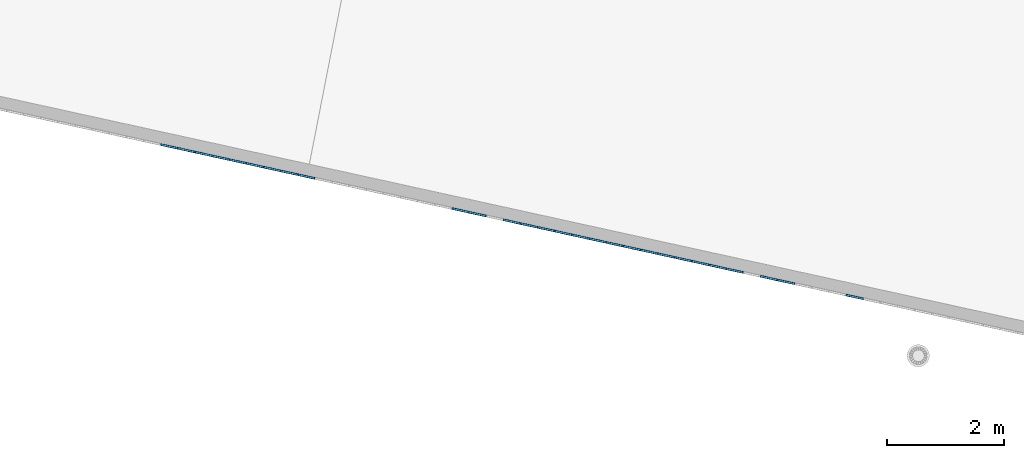
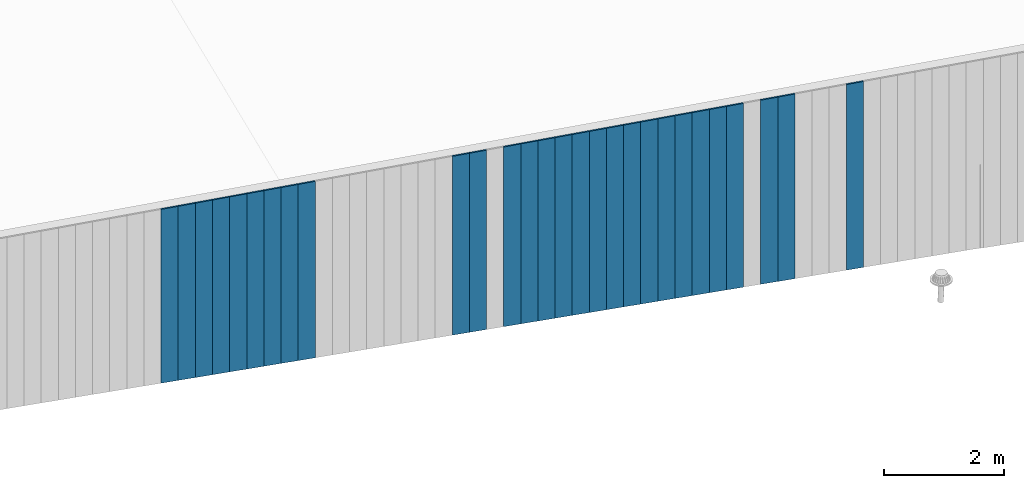
# One storey, part 4 of 18: 28 plates, 1 element without a shape of its own.
"""IFC2X3 building model written with IfcOpenShell, lengths in centimetres."""

from ifc_helpers import new_model, entity, si_unit, converted_unit, derived_unit, direction, frame, origin, place, context, subcontext, project, spatial, polyline, outline, extrude, source, transform, mapped, material, layer, layer_set, layer_usage, type_object, type_shapes, element, aggregate, save


model = new_model("IFC2X3")

# Units and contexts
model_context = context("Model", 3, precision=0.001, world=origin(), true_north=direction((6.12303176911189e-17, 1.0)))
body_context = subcontext(model_context, "Body", "Model", "MODEL_VIEW")
ifc_project = project(units=[si_unit("LENGTHUNIT", "METRE", prefix="CENTI"), si_unit("AREAUNIT", "SQUARE_METRE"), si_unit("VOLUMEUNIT", "CUBIC_METRE"), converted_unit("PLANEANGLEUNIT", "DEGREE", entity("IfcRatioMeasure", 0.0174532925199433), si_unit("PLANEANGLEUNIT", "RADIAN"), dimensions=[0, 0, 0, 0, 0, 0, 0]), si_unit("MASSUNIT", "GRAM", prefix="KILO"), derived_unit("MASSDENSITYUNIT", [(si_unit("MASSUNIT", "GRAM", prefix="KILO"), 1), (si_unit("LENGTHUNIT", "METRE"), -3)]), si_unit("TIMEUNIT", "SECOND"), si_unit("FREQUENCYUNIT", "HERTZ"), si_unit("THERMODYNAMICTEMPERATUREUNIT", "DEGREE_CELSIUS"), derived_unit("THERMALTRANSMITTANCEUNIT", [(si_unit("MASSUNIT", "GRAM", prefix="KILO"), 1), (si_unit("THERMODYNAMICTEMPERATUREUNIT", "KELVIN"), -1), (si_unit("TIMEUNIT", "SECOND"), -3)]), derived_unit("VOLUMETRICFLOWRATEUNIT", [(si_unit("LENGTHUNIT", "METRE"), 3), (si_unit("TIMEUNIT", "SECOND"), -1)]), si_unit("ELECTRICCURRENTUNIT", "AMPERE"), si_unit("ELECTRICVOLTAGEUNIT", "VOLT"), si_unit("POWERUNIT", "WATT"), si_unit("FORCEUNIT", "NEWTON", prefix="KILO"), si_unit("ILLUMINANCEUNIT", "LUX"), si_unit("LUMINOUSFLUXUNIT", "LUMEN"), si_unit("LUMINOUSINTENSITYUNIT", "CANDELA"), derived_unit("USERDEFINED", [(si_unit("MASSUNIT", "GRAM", prefix="KILO"), -1), (si_unit("LENGTHUNIT", "METRE"), -2), (si_unit("TIMEUNIT", "SECOND"), 3), (si_unit("LUMINOUSFLUXUNIT", "LUMEN"), 1)]), derived_unit("LINEARVELOCITYUNIT", [(si_unit("LENGTHUNIT", "METRE"), 1), (si_unit("TIMEUNIT", "SECOND"), -1)]), si_unit("PRESSUREUNIT", "PASCAL"), derived_unit("USERDEFINED", [(si_unit("LENGTHUNIT", "METRE"), -2), (si_unit("MASSUNIT", "GRAM", prefix="KILO"), 1), (si_unit("TIMEUNIT", "SECOND"), -2)])], contexts=[model_context])

# Site, building, storey
site_placement = place(None, origin())
site = spatial("IfcSite", under=ifc_project, at=site_placement, CompositionType="ELEMENT")
building_placement = place(site_placement, origin())
building = spatial("IfcBuilding", under=site, at=building_placement, CompositionType="ELEMENT")
storey_placement = place(building_placement, frame((0.0, 0.0, 1422.0)))
storey = spatial("IfcBuildingStorey", under=building, at=storey_placement, CompositionType="ELEMENT", Elevation=1422.0)

# Curtain wall, plates
curtain_wall_type = type_object("IfcCurtainWallType", PredefinedType="NOTDEFINED")
curtain_wall_placement = place(storey_placement, frame((0.0, 0.0, -1422.0)))
curtain_wall = element("IfcCurtainWall", 1, at=curtain_wall_placement, inside=storey, type_object=curtain_wall_type)
ifc_material = material()
ifc_layer = layer(ifc_material, 3.0)
ifc_layer_set = layer_set([ifc_layer])
ifc_layer_usage_1 = layer_usage(ifc_layer_set, "AXIS3", "POSITIVE", 0.0492125984251968)
plate_type_1 = type_object("IfcPlateType", Name="Panneau plein ST", PredefinedType="CURTAIN_PANEL", material=ifc_layer_set)
shared_shape_1 = source(origin(), body_context, "Body", "SweptSolid", [
    extrude(outline(polyline([(-189.503283067157, -15.0), (189.203717939239, -15.0), (189.203717939239, 15.0), (-188.904152811321, 15.0), (-189.503283067157, -15.0)])), frame((0.0, 0.0, 189.503283067157), z_axis=(0.0, 1.0, 0.0), x_axis=(0.0, 0.0, 1.0)), (0.0, 0.0, 1.0), 3.0),
])
type_shapes(plate_type_1, [shared_shape_1])
plate_1_placement = place(curtain_wall_placement, frame((7422.72421840051, 342.71127905933, 1043.2929989936), z_axis=(0.0, 0.0, 1.0), x_axis=(-0.976731958442773, 0.214463706385357, 0.0)))
plate_1 = element("IfcPlate", 2, at=plate_1_placement, type_object=plate_type_1, material=ifc_layer_usage_1, ObjectType="Panneau plein ST", context=body_context, shape_type="MappedRepresentation", body=[
    mapped(shared_shape_1, transform((0.0, 0.0, 0.0), scale=1.0)),
])
ifc_layer_usage_2 = layer_usage(ifc_layer_set, "AXIS3", "POSITIVE", 0.0492125984251968)
plate_type_2 = type_object("IfcPlateType", Name="Panneau plein ST", PredefinedType="CURTAIN_PANEL", material=ifc_layer_set)
shared_shape_2 = source(origin(), body_context, "Body", "SweptSolid", [
    extrude(outline(polyline([(-188.305022555485, -15.0), (188.005457427567, -15.0), (188.005457427567, 15.0), (-187.705892299649, 15.0), (-188.305022555485, -15.0)])), frame((0.0, 0.0, 188.305022555485), z_axis=(0.0, 1.0, 0.0), x_axis=(0.0, 0.0, 1.0)), (0.0, 0.0, 1.0), 3.0),
])
type_shapes(plate_type_2, [shared_shape_2])
plate_2_placement = place(curtain_wall_placement, frame((7305.51638338737, 368.446923825572, 1045.68952001695), z_axis=(0.0, 0.0, 1.0), x_axis=(-0.976731958442773, 0.214463706385357, 0.0)))
plate_2 = element("IfcPlate", 3, at=plate_2_placement, type_object=plate_type_2, material=ifc_layer_usage_2, ObjectType="Panneau plein ST", context=body_context, shape_type="MappedRepresentation", body=[
    mapped(shared_shape_2, transform((0.0, 0.0, 0.0), scale=1.0)),
])
ifc_layer_usage_3 = layer_usage(ifc_layer_set, "AXIS3", "POSITIVE", 0.0492125984251968)
plate_type_3 = type_object("IfcPlateType", Name="Panneau plein ST", PredefinedType="CURTAIN_PANEL", material=ifc_layer_set)
shared_shape_3 = source(origin(), body_context, "Body", "SweptSolid", [
    extrude(outline(polyline([(-188.005457427567, -15.0), (187.705892299649, -15.0), (187.705892299649, 15.0), (-187.406327171731, 15.0), (-188.005457427567, -15.0)])), frame((0.0, 0.0, 188.005457427567), z_axis=(0.0, 1.0, 0.0), x_axis=(0.0, 0.0, 1.0)), (0.0, 0.0, 1.0), 3.0),
])
type_shapes(plate_type_3, [shared_shape_3])
plate_3_placement = place(curtain_wall_placement, frame((7276.21442463409, 374.880835017134, 1046.28865027278), z_axis=(0.0, 0.0, 1.0), x_axis=(-0.976731958442773, 0.214463706385357, 0.0)))
plate_3 = element("IfcPlate", 4, at=plate_3_placement, type_object=plate_type_3, material=ifc_layer_usage_3, ObjectType="Panneau plein ST", context=body_context, shape_type="MappedRepresentation", body=[
    mapped(shared_shape_3, transform((0.0, 0.0, 0.0), scale=1.0)),
])
ifc_layer_usage_4 = layer_usage(ifc_layer_set, "AXIS3", "POSITIVE", 0.0492125984251968)
plate_type_4 = type_object("IfcPlateType", Name="Panneau plein ST", PredefinedType="CURTAIN_PANEL", material=ifc_layer_set)
shared_shape_4 = source(origin(), body_context, "Body", "SweptSolid", [
    extrude(outline(polyline([(-187.406327171731, -15.0), (187.106762043813, -15.0), (187.106762043813, 15.0), (-186.807196915895, 15.0), (-187.406327171731, -15.0)])), frame((0.0, 0.0, 187.406327171731), z_axis=(0.0, 1.0, 0.0), x_axis=(0.0, 0.0, 1.0)), (0.0, 0.0, 1.0), 3.0),
])
type_shapes(plate_type_4, [shared_shape_4])
plate_4_placement = place(curtain_wall_placement, frame((7217.61050712753, 387.748657400255, 1047.48691078446), z_axis=(0.0, 0.0, 1.0), x_axis=(-0.976731958442773, 0.214463706385357, 0.0)))
plate_4 = element("IfcPlate", 5, at=plate_4_placement, type_object=plate_type_4, material=ifc_layer_usage_4, ObjectType="Panneau plein ST", context=body_context, shape_type="MappedRepresentation", body=[
    mapped(shared_shape_4, transform((0.0, 0.0, 0.0), scale=1.0)),
])
ifc_layer_usage_5 = layer_usage(ifc_layer_set, "AXIS3", "POSITIVE", 0.0492125984251968)
plate_type_5 = type_object("IfcPlateType", Name="Panneau plein ST", PredefinedType="CURTAIN_PANEL", material=ifc_layer_set)
shared_shape_5 = source(origin(), body_context, "Body", "SweptSolid", [
    extrude(outline(polyline([(-187.106762043813, -15.0), (186.807196915895, -15.0), (186.807196915895, 15.0), (-186.507631787977, 15.0), (-187.106762043813, -15.0)])), frame((0.0, 0.0, 187.106762043813), z_axis=(0.0, 1.0, 0.0), x_axis=(0.0, 0.0, 1.0)), (0.0, 0.0, 1.0), 3.0),
])
type_shapes(plate_type_5, [shared_shape_5])
plate_5_placement = place(curtain_wall_placement, frame((7188.30854837424, 394.182568591816, 1048.08604104029), z_axis=(0.0, 0.0, 1.0), x_axis=(-0.976731958442773, 0.214463706385357, 0.0)))
plate_5 = element("IfcPlate", 6, at=plate_5_placement, type_object=plate_type_5, material=ifc_layer_usage_5, ObjectType="Panneau plein ST", context=body_context, shape_type="MappedRepresentation", body=[
    mapped(shared_shape_5, transform((0.0, 0.0, 0.0), scale=1.0)),
])
ifc_layer_usage_6 = layer_usage(ifc_layer_set, "AXIS3", "POSITIVE", 0.0492125984251968)
plate_type_6 = type_object("IfcPlateType", Name="Panneau plein ST", PredefinedType="CURTAIN_PANEL", material=ifc_layer_set)
shared_shape_6 = source(origin(), body_context, "Body", "SweptSolid", [
    extrude(outline(polyline([(-186.807196915895, -15.0), (186.507631787977, -15.0), (186.507631787977, 15.0), (-186.208066660059, 15.0), (-186.807196915895, -15.0)])), frame((0.0, 0.0, 186.807196915895), z_axis=(0.0, 1.0, 0.0), x_axis=(0.0, 0.0, 1.0)), (0.0, 0.0, 1.0), 3.0),
])
type_shapes(plate_type_6, [shared_shape_6])
plate_6_placement = place(curtain_wall_placement, frame((7159.00658962096, 400.616479783376, 1048.68517129613), z_axis=(0.0, 0.0, 1.0), x_axis=(-0.976731958442773, 0.214463706385357, 0.0)))
plate_6 = element("IfcPlate", 7, at=plate_6_placement, type_object=plate_type_6, material=ifc_layer_usage_6, ObjectType="Panneau plein ST", context=body_context, shape_type="MappedRepresentation", body=[
    mapped(shared_shape_6, transform((0.0, 0.0, 0.0), scale=1.0)),
])
ifc_layer_usage_7 = layer_usage(ifc_layer_set, "AXIS3", "POSITIVE", 0.0492125984251968)
plate_type_7 = type_object("IfcPlateType", Name="Panneau plein ST", PredefinedType="CURTAIN_PANEL", material=ifc_layer_set)
shared_shape_7 = source(origin(), body_context, "Body", "SweptSolid", [
    extrude(outline(polyline([(-186.507631787977, -15.0), (186.208066660059, -15.0), (186.208066660059, 15.0), (-185.908501532141, 15.0), (-186.507631787977, -15.0)])), frame((0.0, 0.0, 186.507631787977), z_axis=(0.0, 1.0, 0.0), x_axis=(0.0, 0.0, 1.0)), (0.0, 0.0, 1.0), 3.0),
])
type_shapes(plate_type_7, [shared_shape_7])
plate_7_placement = place(curtain_wall_placement, frame((7129.70463086767, 407.050390974937, 1049.28430155196), z_axis=(0.0, 0.0, 1.0), x_axis=(-0.976731958442773, 0.214463706385357, 0.0)))
plate_7 = element("IfcPlate", 8, at=plate_7_placement, type_object=plate_type_7, material=ifc_layer_usage_7, ObjectType="Panneau plein ST", context=body_context, shape_type="MappedRepresentation", body=[
    mapped(shared_shape_7, transform((0.0, 0.0, 0.0), scale=1.0)),
])
ifc_layer_usage_8 = layer_usage(ifc_layer_set, "AXIS3", "POSITIVE", 0.0492125984251968)
plate_type_8 = type_object("IfcPlateType", Name="Panneau plein ST", PredefinedType="CURTAIN_PANEL", material=ifc_layer_set)
shared_shape_8 = source(origin(), body_context, "Body", "SweptSolid", [
    extrude(outline(polyline([(-186.208066660059, -15.0), (185.908501532141, -15.0), (185.908501532141, 15.0), (-185.608936404223, 15.0), (-186.208066660059, -15.0)])), frame((0.0, 0.0, 186.208066660059), z_axis=(0.0, 1.0, 0.0), x_axis=(0.0, 0.0, 1.0)), (0.0, 0.0, 1.0), 3.0),
])
type_shapes(plate_type_8, [shared_shape_8])
plate_8_placement = place(curtain_wall_placement, frame((7100.40267211439, 413.484302166498, 1049.8834318078), z_axis=(0.0, 0.0, 1.0), x_axis=(-0.976731958442773, 0.214463706385357, 0.0)))
plate_8 = element("IfcPlate", 9, at=plate_8_placement, type_object=plate_type_8, material=ifc_layer_usage_8, ObjectType="Panneau plein ST", context=body_context, shape_type="MappedRepresentation", body=[
    mapped(shared_shape_8, transform((0.0, 0.0, 0.0), scale=1.0)),
])
ifc_layer_usage_9 = layer_usage(ifc_layer_set, "AXIS3", "POSITIVE", 0.0492125984251968)
plate_type_9 = type_object("IfcPlateType", Name="Panneau plein ST", PredefinedType="CURTAIN_PANEL", material=ifc_layer_set)
shared_shape_9 = source(origin(), body_context, "Body", "SweptSolid", [
    extrude(outline(polyline([(-185.908501532141, -15.0), (185.608936404223, -15.0), (185.608936404223, 15.0), (-185.309371276305, 15.0), (-185.908501532141, -15.0)])), frame((0.0, 0.0, 185.908501532141), z_axis=(0.0, 1.0, 0.0), x_axis=(0.0, 0.0, 1.0)), (0.0, 0.0, 1.0), 3.0),
])
type_shapes(plate_type_9, [shared_shape_9])
plate_9_placement = place(curtain_wall_placement, frame((7071.10071336111, 419.918213358058, 1050.48256206364), z_axis=(0.0, 0.0, 1.0), x_axis=(-0.976731958442773, 0.214463706385357, 0.0)))
plate_9 = element("IfcPlate", 10, at=plate_9_placement, type_object=plate_type_9, material=ifc_layer_usage_9, ObjectType="Panneau plein ST", context=body_context, shape_type="MappedRepresentation", body=[
    mapped(shared_shape_9, transform((0.0, 0.0, 0.0), scale=1.0)),
])
ifc_layer_usage_10 = layer_usage(ifc_layer_set, "AXIS3", "POSITIVE", 0.0492125984251968)
plate_type_10 = type_object("IfcPlateType", Name="Panneau plein ST", PredefinedType="CURTAIN_PANEL", material=ifc_layer_set)
shared_shape_10 = source(origin(), body_context, "Body", "SweptSolid", [
    extrude(outline(polyline([(-185.608936404223, -15.0), (185.309371276305, -15.0), (185.309371276305, 15.0), (-185.009806148387, 15.0), (-185.608936404223, -15.0)])), frame((0.0, 0.0, 185.608936404223), z_axis=(0.0, 1.0, 0.0), x_axis=(0.0, 0.0, 1.0)), (0.0, 0.0, 1.0), 3.0),
])
type_shapes(plate_type_10, [shared_shape_10])
plate_10_placement = place(curtain_wall_placement, frame((7041.79875460782, 426.352124549619, 1051.08169231947), z_axis=(0.0, 0.0, 1.0), x_axis=(-0.976731958442773, 0.214463706385357, 0.0)))
plate_10 = element("IfcPlate", 11, at=plate_10_placement, type_object=plate_type_10, material=ifc_layer_usage_10, ObjectType="Panneau plein ST", context=body_context, shape_type="MappedRepresentation", body=[
    mapped(shared_shape_10, transform((0.0, 0.0, 0.0), scale=1.0)),
])
ifc_layer_usage_11 = layer_usage(ifc_layer_set, "AXIS3", "POSITIVE", 0.0492125984251968)
plate_type_11 = type_object("IfcPlateType", Name="Panneau plein ST", PredefinedType="CURTAIN_PANEL", material=ifc_layer_set)
shared_shape_11 = source(origin(), body_context, "Body", "SweptSolid", [
    extrude(outline(polyline([(-185.309371276305, -15.0), (185.009806148387, -15.0), (185.009806148387, 15.0), (-184.710241020469, 15.0), (-185.309371276305, -15.0)])), frame((0.0, 0.0, 185.309371276305), z_axis=(0.0, 1.0, 0.0), x_axis=(0.0, 0.0, 1.0)), (0.0, 0.0, 1.0), 3.0),
])
type_shapes(plate_type_11, [shared_shape_11])
plate_11_placement = place(curtain_wall_placement, frame((7012.49679585454, 432.78603574118, 1051.68082257531), z_axis=(0.0, 0.0, 1.0), x_axis=(-0.976731958442773, 0.214463706385357, 0.0)))
plate_11 = element("IfcPlate", 12, at=plate_11_placement, type_object=plate_type_11, material=ifc_layer_usage_11, ObjectType="Panneau plein ST", context=body_context, shape_type="MappedRepresentation", body=[
    mapped(shared_shape_11, transform((0.0, 0.0, 0.0), scale=1.0)),
])
ifc_layer_usage_12 = layer_usage(ifc_layer_set, "AXIS3", "POSITIVE", 0.0492125984251968)
plate_type_12 = type_object("IfcPlateType", Name="Panneau plein ST", PredefinedType="CURTAIN_PANEL", material=ifc_layer_set)
shared_shape_12 = source(origin(), body_context, "Body", "SweptSolid", [
    extrude(outline(polyline([(-185.009806148387, -15.0), (184.710241020469, -15.0), (184.710241020469, 15.0), (-184.410675892551, 15.0), (-185.009806148387, -15.0)])), frame((0.0, 0.0, 185.009806148387), z_axis=(0.0, 1.0, 0.0), x_axis=(0.0, 0.0, 1.0)), (0.0, 0.0, 1.0), 3.0),
])
type_shapes(plate_type_12, [shared_shape_12])
plate_12_placement = place(curtain_wall_placement, frame((6983.19483710126, 439.219946932741, 1052.27995283114), z_axis=(0.0, 0.0, 1.0), x_axis=(-0.976731958442773, 0.214463706385357, 0.0)))
plate_12 = element("IfcPlate", 13, at=plate_12_placement, type_object=plate_type_12, material=ifc_layer_usage_12, ObjectType="Panneau plein ST", context=body_context, shape_type="MappedRepresentation", body=[
    mapped(shared_shape_12, transform((0.0, 0.0, 0.0), scale=1.0)),
])
ifc_layer_usage_13 = layer_usage(ifc_layer_set, "AXIS3", "POSITIVE", 0.0492125984251968)
plate_type_13 = type_object("IfcPlateType", Name="Panneau plein ST", PredefinedType="CURTAIN_PANEL", material=ifc_layer_set)
shared_shape_13 = source(origin(), body_context, "Body", "SweptSolid", [
    extrude(outline(polyline([(-184.710241020469, -15.0), (184.410675892551, -15.0), (184.410675892551, 15.0), (-184.111110764633, 15.0), (-184.710241020469, -15.0)])), frame((0.0, 0.0, 184.710241020469), z_axis=(0.0, 1.0, 0.0), x_axis=(0.0, 0.0, 1.0)), (0.0, 0.0, 1.0), 3.0),
])
type_shapes(plate_type_13, [shared_shape_13])
plate_13_placement = place(curtain_wall_placement, frame((6953.89287834797, 445.653858124301, 1052.87908308698), z_axis=(0.0, 0.0, 1.0), x_axis=(-0.976731958442773, 0.214463706385357, 0.0)))
plate_13 = element("IfcPlate", 14, at=plate_13_placement, type_object=plate_type_13, material=ifc_layer_usage_13, ObjectType="Panneau plein ST", context=body_context, shape_type="MappedRepresentation", body=[
    mapped(shared_shape_13, transform((0.0, 0.0, 0.0), scale=1.0)),
])
ifc_layer_usage_14 = layer_usage(ifc_layer_set, "AXIS3", "POSITIVE", 0.0492125984251968)
plate_type_14 = type_object("IfcPlateType", Name="Panneau plein ST", PredefinedType="CURTAIN_PANEL", material=ifc_layer_set)
shared_shape_14 = source(origin(), body_context, "Body", "SweptSolid", [
    extrude(outline(polyline([(-184.410675892551, -15.0), (184.111110764633, -15.0), (184.111110764633, 15.0), (-183.811545636715, 15.0), (-184.410675892551, -15.0)])), frame((0.0, 0.0, 184.410675892551), z_axis=(0.0, 1.0, 0.0), x_axis=(0.0, 0.0, 1.0)), (0.0, 0.0, 1.0), 3.0),
])
type_shapes(plate_type_14, [shared_shape_14])
plate_14_placement = place(curtain_wall_placement, frame((6924.59091959469, 452.087769315862, 1053.47821334282), z_axis=(0.0, 0.0, 1.0), x_axis=(-0.976731958442773, 0.214463706385357, 0.0)))
plate_14 = element("IfcPlate", 15, at=plate_14_placement, type_object=plate_type_14, material=ifc_layer_usage_14, ObjectType="Panneau plein ST", context=body_context, shape_type="MappedRepresentation", body=[
    mapped(shared_shape_14, transform((0.0, 0.0, 0.0), scale=1.0)),
])
ifc_layer_usage_15 = layer_usage(ifc_layer_set, "AXIS3", "POSITIVE", 0.0492125984251968)
plate_type_15 = type_object("IfcPlateType", Name="Panneau plein ST", PredefinedType="CURTAIN_PANEL", material=ifc_layer_set)
shared_shape_15 = source(origin(), body_context, "Body", "SweptSolid", [
    extrude(outline(polyline([(-184.111110764633, -15.0), (183.811545636715, -15.0), (183.811545636715, 15.0), (-183.511980508797, 15.0), (-184.111110764633, -15.0)])), frame((0.0, 0.0, 184.111110764633), z_axis=(0.0, 1.0, 0.0), x_axis=(0.0, 0.0, 1.0)), (0.0, 0.0, 1.0), 3.0),
])
type_shapes(plate_type_15, [shared_shape_15])
plate_15_placement = place(curtain_wall_placement, frame((6895.28896084141, 458.521680507423, 1054.07734359865), z_axis=(0.0, 0.0, 1.0), x_axis=(-0.976731958442773, 0.214463706385357, 0.0)))
plate_15 = element("IfcPlate", 16, at=plate_15_placement, type_object=plate_type_15, material=ifc_layer_usage_15, ObjectType="Panneau plein ST", context=body_context, shape_type="MappedRepresentation", body=[
    mapped(shared_shape_15, transform((0.0, 0.0, 0.0), scale=1.0)),
])
ifc_layer_usage_16 = layer_usage(ifc_layer_set, "AXIS3", "POSITIVE", 0.0492125984251968)
plate_type_16 = type_object("IfcPlateType", Name="Panneau plein ST", PredefinedType="CURTAIN_PANEL", material=ifc_layer_set)
shared_shape_16 = source(origin(), body_context, "Body", "SweptSolid", [
    extrude(outline(polyline([(-183.811545636715, -15.0), (183.511980508797, -15.0), (183.511980508797, 15.0), (-183.212415380879, 15.0), (-183.811545636715, -15.0)])), frame((0.0, 0.0, 183.811545636715), z_axis=(0.0, 1.0, 0.0), x_axis=(0.0, 0.0, 1.0)), (0.0, 0.0, 1.0), 3.0),
])
type_shapes(plate_type_16, [shared_shape_16])
plate_16_placement = place(curtain_wall_placement, frame((6865.98700208812, 464.955591698984, 1054.67647385449), z_axis=(0.0, 0.0, 1.0), x_axis=(-0.976731958442773, 0.214463706385357, 0.0)))
plate_16 = element("IfcPlate", 17, at=plate_16_placement, type_object=plate_type_16, material=ifc_layer_usage_16, ObjectType="Panneau plein ST", context=body_context, shape_type="MappedRepresentation", body=[
    mapped(shared_shape_16, transform((0.0, 0.0, 0.0), scale=1.0)),
])
ifc_layer_usage_17 = layer_usage(ifc_layer_set, "AXIS3", "POSITIVE", 0.0492125984251968)
plate_type_17 = type_object("IfcPlateType", Name="Panneau plein ST", PredefinedType="CURTAIN_PANEL", material=ifc_layer_set)
shared_shape_17 = source(origin(), body_context, "Body", "SweptSolid", [
    extrude(outline(polyline([(-183.511980508797, -15.0), (183.212415380879, -15.0), (183.212415380879, 15.0), (-182.912850252961, 15.0), (-183.511980508797, -15.0)])), frame((0.0, 0.0, 183.511980508797), z_axis=(0.0, 1.0, 0.0), x_axis=(0.0, 0.0, 1.0)), (0.0, 0.0, 1.0), 3.0),
])
type_shapes(plate_type_17, [shared_shape_17])
plate_17_placement = place(curtain_wall_placement, frame((6836.68504333484, 471.389502890544, 1055.27560411032), z_axis=(0.0, 0.0, 1.0), x_axis=(-0.976731958442773, 0.214463706385357, 0.0)))
plate_17 = element("IfcPlate", 18, at=plate_17_placement, type_object=plate_type_17, material=ifc_layer_usage_17, ObjectType="Panneau plein ST", context=body_context, shape_type="MappedRepresentation", body=[
    mapped(shared_shape_17, transform((0.0, 0.0, 0.0), scale=1.0)),
])
ifc_layer_usage_18 = layer_usage(ifc_layer_set, "AXIS3", "POSITIVE", 0.0492125984251968)
plate_type_18 = type_object("IfcPlateType", Name="Panneau plein ST", PredefinedType="CURTAIN_PANEL", material=ifc_layer_set)
shared_shape_18 = source(origin(), body_context, "Body", "SweptSolid", [
    extrude(outline(polyline([(-182.912850252961, -15.0), (182.613285125043, -15.0), (182.613285125043, 15.0), (-182.313719997125, 15.0), (-182.912850252961, -15.0)])), frame((0.0, 0.0, 182.912850252961), z_axis=(0.0, 1.0, 0.0), x_axis=(0.0, 0.0, 1.0)), (0.0, 0.0, 1.0), 3.0),
])
type_shapes(plate_type_18, [shared_shape_18])
plate_18_placement = place(curtain_wall_placement, frame((6778.08112582827, 484.257325273666, 1056.473864622), z_axis=(0.0, 0.0, 1.0), x_axis=(-0.976731958442773, 0.214463706385357, 0.0)))
plate_18 = element("IfcPlate", 19, at=plate_18_placement, type_object=plate_type_18, material=ifc_layer_usage_18, ObjectType="Panneau plein ST", context=body_context, shape_type="MappedRepresentation", body=[
    mapped(shared_shape_18, transform((0.0, 0.0, 0.0), scale=1.0)),
])
ifc_layer_usage_19 = layer_usage(ifc_layer_set, "AXIS3", "POSITIVE", 0.0492125984251968)
plate_type_19 = type_object("IfcPlateType", Name="Panneau plein ST", PredefinedType="CURTAIN_PANEL", material=ifc_layer_set)
shared_shape_19 = source(origin(), body_context, "Body", "SweptSolid", [
    extrude(outline(polyline([(-182.613285125043, -15.0), (182.313719997125, -15.0), (182.313719997125, 15.0), (-182.014154869207, 15.0), (-182.613285125043, -15.0)])), frame((0.0, 0.0, 182.613285125043), z_axis=(0.0, 1.0, 0.0), x_axis=(0.0, 0.0, 1.0)), (0.0, 0.0, 1.0), 3.0),
])
type_shapes(plate_type_19, [shared_shape_19])
plate_19_placement = place(curtain_wall_placement, frame((6748.77916707499, 490.691236465227, 1057.07299487783), z_axis=(0.0, 0.0, 1.0), x_axis=(-0.976731958442773, 0.214463706385357, 0.0)))
plate_19 = element("IfcPlate", 20, at=plate_19_placement, type_object=plate_type_19, material=ifc_layer_usage_19, ObjectType="Panneau plein ST", context=body_context, shape_type="MappedRepresentation", body=[
    mapped(shared_shape_19, transform((0.0, 0.0, 0.0), scale=1.0)),
])
ifc_layer_usage_20 = layer_usage(ifc_layer_set, "AXIS3", "POSITIVE", 0.0492125984251968)
plate_type_20 = type_object("IfcPlateType", Name="Panneau plein ST", PredefinedType="CURTAIN_PANEL", material=ifc_layer_set)
shared_shape_20 = source(origin(), body_context, "Body", "SweptSolid", [
    extrude(outline(polyline([(-179.917198973781, -15.0), (179.617633845863, -15.0), (179.617633845863, 15.0), (-179.318068717945, 15.0), (-179.917198973781, -15.0)])), frame((0.0, 0.0, 179.917198973781), z_axis=(0.0, 1.0, 0.0), x_axis=(0.0, 0.0, 1.0)), (0.0, 0.0, 1.0), 3.0),
])
type_shapes(plate_type_20, [shared_shape_20])
plate_20_placement = place(curtain_wall_placement, frame((6485.06153829544, 548.596437189273, 1062.46516718036), z_axis=(0.0, 0.0, 1.0), x_axis=(-0.976731958442773, 0.214463706385357, 0.0)))
plate_20 = element("IfcPlate", 21, at=plate_20_placement, type_object=plate_type_20, material=ifc_layer_usage_20, ObjectType="Panneau plein ST", context=body_context, shape_type="MappedRepresentation", body=[
    mapped(shared_shape_20, transform((0.0, 0.0, 0.0), scale=1.0)),
])
ifc_layer_usage_21 = layer_usage(ifc_layer_set, "AXIS3", "POSITIVE", 0.0492125984251968)
plate_type_21 = type_object("IfcPlateType", Name="Panneau plein ST", PredefinedType="CURTAIN_PANEL", material=ifc_layer_set)
shared_shape_21 = source(origin(), body_context, "Body", "SweptSolid", [
    extrude(outline(polyline([(-179.617633845863, -15.0), (179.318068717945, -15.0), (179.318068717945, 15.0), (-179.018503590027, 15.0), (-179.617633845863, -15.0)])), frame((0.0, 0.0, 179.617633845863), z_axis=(0.0, 1.0, 0.0), x_axis=(0.0, 0.0, 1.0)), (0.0, 0.0, 1.0), 3.0),
])
type_shapes(plate_type_21, [shared_shape_21])
plate_21_placement = place(curtain_wall_placement, frame((6455.75957954216, 555.030348380834, 1063.06429743619), z_axis=(0.0, 0.0, 1.0), x_axis=(-0.976731958442773, 0.214463706385357, 0.0)))
plate_21 = element("IfcPlate", 22, at=plate_21_placement, type_object=plate_type_21, material=ifc_layer_usage_21, ObjectType="Panneau plein ST", context=body_context, shape_type="MappedRepresentation", body=[
    mapped(shared_shape_21, transform((0.0, 0.0, 0.0), scale=1.0)),
])
ifc_layer_usage_22 = layer_usage(ifc_layer_set, "AXIS3", "POSITIVE", 0.0492125984251968)
plate_type_22 = type_object("IfcPlateType", Name="Panneau plein ST", PredefinedType="CURTAIN_PANEL", material=ifc_layer_set)
shared_shape_22 = source(origin(), body_context, "Body", "SweptSolid", [
    extrude(outline(polyline([(-179.318068717945, -15.0), (179.018503590027, -15.0), (179.018503590027, 15.0), (-178.718938462109, 15.0), (-179.318068717945, -15.0)])), frame((0.0, 0.0, 179.318068717945), z_axis=(0.0, 1.0, 0.0), x_axis=(0.0, 0.0, 1.0)), (0.0, 0.0, 1.0), 3.0),
])
type_shapes(plate_type_22, [shared_shape_22])
plate_22_placement = place(curtain_wall_placement, frame((6426.45762078887, 561.464259572394, 1063.66342769203), z_axis=(0.0, 0.0, 1.0), x_axis=(-0.976731958442773, 0.214463706385357, 0.0)))
plate_22 = element("IfcPlate", 23, at=plate_22_placement, type_object=plate_type_22, material=ifc_layer_usage_22, ObjectType="Panneau plein ST", context=body_context, shape_type="MappedRepresentation", body=[
    mapped(shared_shape_22, transform((0.0, 0.0, 0.0), scale=1.0)),
])
ifc_layer_usage_23 = layer_usage(ifc_layer_set, "AXIS3", "POSITIVE", 0.0492125984251968)
plate_type_23 = type_object("IfcPlateType", Name="Panneau plein ST", PredefinedType="CURTAIN_PANEL", material=ifc_layer_set)
shared_shape_23 = source(origin(), body_context, "Body", "SweptSolid", [
    extrude(outline(polyline([(-179.018503590027, -15.0), (178.718938462109, -15.0), (178.718938462109, 15.0), (-178.419373334191, 15.0), (-179.018503590027, -15.0)])), frame((0.0, 0.0, 179.018503590027), z_axis=(0.0, 1.0, 0.0), x_axis=(0.0, 0.0, 1.0)), (0.0, 0.0, 1.0), 3.0),
])
type_shapes(plate_type_23, [shared_shape_23])
plate_23_placement = place(curtain_wall_placement, frame((6397.15566203559, 567.898170763955, 1064.26255794786), z_axis=(0.0, 0.0, 1.0), x_axis=(-0.976731958442773, 0.214463706385357, 0.0)))
plate_23 = element("IfcPlate", 24, at=plate_23_placement, type_object=plate_type_23, material=ifc_layer_usage_23, ObjectType="Panneau plein ST", context=body_context, shape_type="MappedRepresentation", body=[
    mapped(shared_shape_23, transform((0.0, 0.0, 0.0), scale=1.0)),
])
ifc_layer_usage_24 = layer_usage(ifc_layer_set, "AXIS3", "POSITIVE", 0.0492125984251968)
plate_type_24 = type_object("IfcPlateType", Name="Panneau plein ST", PredefinedType="CURTAIN_PANEL", material=ifc_layer_set)
shared_shape_24 = source(origin(), body_context, "Body", "SweptSolid", [
    extrude(outline(polyline([(-178.718938462109, -15.0), (178.419373334191, -15.0), (178.419373334191, 15.0), (-178.119808206273, 15.0), (-178.718938462109, -15.0)])), frame((0.0, 0.0, 178.718938462109), z_axis=(0.0, 1.0, 0.0), x_axis=(0.0, 0.0, 1.0)), (0.0, 0.0, 1.0), 3.0),
])
type_shapes(plate_type_24, [shared_shape_24])
plate_24_placement = place(curtain_wall_placement, frame((6367.85370328231, 574.332081955516, 1064.8616882037), z_axis=(0.0, 0.0, 1.0), x_axis=(-0.976731958442773, 0.214463706385357, 0.0)))
plate_24 = element("IfcPlate", 25, at=plate_24_placement, type_object=plate_type_24, material=ifc_layer_usage_24, ObjectType="Panneau plein ST", context=body_context, shape_type="MappedRepresentation", body=[
    mapped(shared_shape_24, transform((0.0, 0.0, 0.0), scale=1.0)),
])
ifc_layer_usage_25 = layer_usage(ifc_layer_set, "AXIS3", "POSITIVE", 0.0492125984251968)
plate_type_25 = type_object("IfcPlateType", Name="Panneau plein ST", PredefinedType="CURTAIN_PANEL", material=ifc_layer_set)
shared_shape_25 = source(origin(), body_context, "Body", "SweptSolid", [
    extrude(outline(polyline([(-178.419373334191, -15.0), (178.119808206273, -15.0), (178.119808206273, 15.0), (-177.820243078355, 15.0), (-178.419373334191, -15.0)])), frame((0.0, 0.0, 178.419373334191), z_axis=(0.0, 1.0, 0.0), x_axis=(0.0, 0.0, 1.0)), (0.0, 0.0, 1.0), 3.0),
])
type_shapes(plate_type_25, [shared_shape_25])
plate_25_placement = place(curtain_wall_placement, frame((6338.55174452903, 580.765993147076, 1065.46081845954), z_axis=(0.0, 0.0, 1.0), x_axis=(-0.976731958442773, 0.214463706385357, 0.0)))
plate_25 = element("IfcPlate", 26, at=plate_25_placement, type_object=plate_type_25, material=ifc_layer_usage_25, ObjectType="Panneau plein ST", context=body_context, shape_type="MappedRepresentation", body=[
    mapped(shared_shape_25, transform((0.0, 0.0, 0.0), scale=1.0)),
])
ifc_layer_usage_26 = layer_usage(ifc_layer_set, "AXIS3", "POSITIVE", 0.0492125984251968)
plate_type_26 = type_object("IfcPlateType", Name="Panneau plein ST", PredefinedType="CURTAIN_PANEL", material=ifc_layer_set)
shared_shape_26 = source(origin(), body_context, "Body", "SweptSolid", [
    extrude(outline(polyline([(-178.119808206273, -15.0), (177.820243078355, -15.0), (177.820243078355, 15.0), (-177.520677950437, 15.0), (-178.119808206273, -15.0)])), frame((0.0, 0.0, 178.119808206273), z_axis=(0.0, 1.0, 0.0), x_axis=(0.0, 0.0, 1.0)), (0.0, 0.0, 1.0), 3.0),
])
type_shapes(plate_type_26, [shared_shape_26])
plate_26_placement = place(curtain_wall_placement, frame((6309.24978577574, 587.199904338637, 1066.05994871537), z_axis=(0.0, 0.0, 1.0), x_axis=(-0.976731958442773, 0.214463706385357, 0.0)))
plate_26 = element("IfcPlate", 27, at=plate_26_placement, type_object=plate_type_26, material=ifc_layer_usage_26, ObjectType="Panneau plein ST", context=body_context, shape_type="MappedRepresentation", body=[
    mapped(shared_shape_26, transform((0.0, 0.0, 0.0), scale=1.0)),
])
ifc_layer_usage_27 = layer_usage(ifc_layer_set, "AXIS3", "POSITIVE", 0.0492125984251968)
plate_type_27 = type_object("IfcPlateType", Name="Panneau plein ST", PredefinedType="CURTAIN_PANEL", material=ifc_layer_set)
shared_shape_27 = source(origin(), body_context, "Body", "SweptSolid", [
    extrude(outline(polyline([(-177.820243078355, -15.0), (177.520677950437, -15.0), (177.520677950437, 15.0), (-177.221112822519, 15.0), (-177.820243078355, -15.0)])), frame((0.0, 0.0, 177.820243078355), z_axis=(0.0, 1.0, 0.0), x_axis=(0.0, 0.0, 1.0)), (0.0, 0.0, 1.0), 3.0),
])
type_shapes(plate_type_27, [shared_shape_27])
plate_27_placement = place(curtain_wall_placement, frame((6279.94782702246, 593.633815530198, 1066.65907897121), z_axis=(0.0, 0.0, 1.0), x_axis=(-0.976731958442773, 0.214463706385357, 0.0)))
plate_27 = element("IfcPlate", 28, at=plate_27_placement, type_object=plate_type_27, material=ifc_layer_usage_27, ObjectType="Panneau plein ST", context=body_context, shape_type="MappedRepresentation", body=[
    mapped(shared_shape_27, transform((0.0, 0.0, 0.0), scale=1.0)),
])
ifc_layer_usage_28 = layer_usage(ifc_layer_set, "AXIS3", "POSITIVE", 0.0492125984251968)
plate_type_28 = type_object("IfcPlateType", Name="Panneau plein ST", PredefinedType="CURTAIN_PANEL", material=ifc_layer_set)
shared_shape_28 = source(origin(), body_context, "Body", "SweptSolid", [
    extrude(outline(polyline([(-177.520677950437, -15.0), (177.221112822519, -15.0), (177.221112822519, 15.0), (-176.921547694601, 15.0), (-177.520677950437, -15.0)])), frame((0.0, 0.0, 177.520677950437), z_axis=(0.0, 1.0, 0.0), x_axis=(0.0, 0.0, 1.0)), (0.0, 0.0, 1.0), 3.0),
])
type_shapes(plate_type_28, [shared_shape_28])
plate_28_placement = place(curtain_wall_placement, frame((6250.64586826917, 600.067726721759, 1067.25820922704), z_axis=(0.0, 0.0, 1.0), x_axis=(-0.976731958442773, 0.214463706385357, 0.0)))
plate_28 = element("IfcPlate", 29, at=plate_28_placement, type_object=plate_type_28, material=ifc_layer_usage_28, ObjectType="Panneau plein ST", context=body_context, shape_type="MappedRepresentation", body=[
    mapped(shared_shape_28, transform((0.0, 0.0, 0.0), scale=1.0)),
])
aggregate(curtain_wall, [plate_1, plate_2, plate_3, plate_4, plate_5, plate_6, plate_7, plate_8, plate_9, plate_10, plate_11, plate_12, plate_13, plate_14, plate_15, plate_16, plate_17, plate_18, plate_19, plate_20, plate_21, plate_22, plate_23, plate_24, plate_25, plate_26, plate_27, plate_28])

save(model, "model.ifc")
